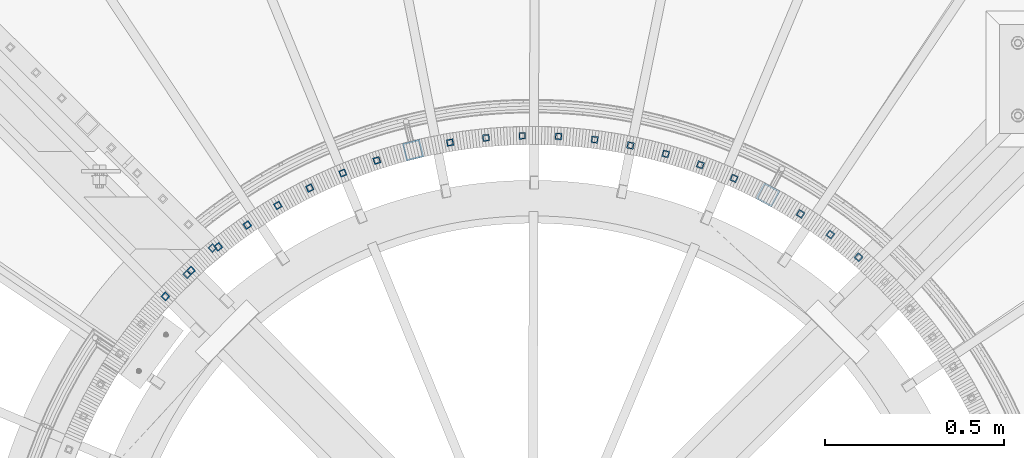
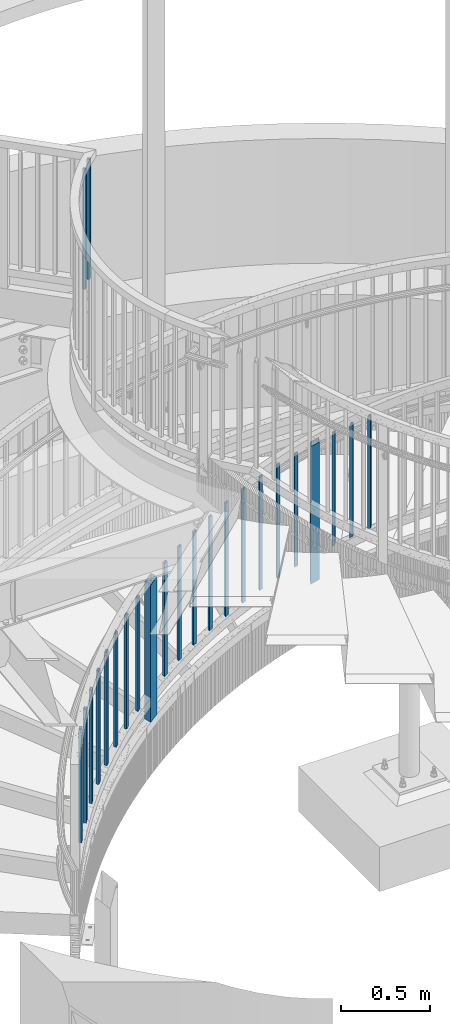
# One storey, part 264 of 975: 24 columns.
"""IFC2X3 building model written with IfcOpenShell, lengths in millimetres."""

from ifc_helpers import new_model, si_unit, frame, origin_with_axes, place, context, subcontext, project, spatial, faceted_brep, material, type_object, element, save


model = new_model("IFC2X3")

# Units and contexts
model_context = context("Model", 3, precision=1e-05, world=origin_with_axes())
body_context = subcontext(model_context, "Body", "Model", "MODEL_VIEW")
ifc_project = project(units=[si_unit("LENGTHUNIT", "METRE", prefix="MILLI"), si_unit("AREAUNIT", "SQUARE_METRE"), si_unit("VOLUMEUNIT", "CUBIC_METRE"), si_unit("MASSUNIT", "GRAM", prefix="KILO"), si_unit("TIMEUNIT", "SECOND"), si_unit("PLANEANGLEUNIT", "RADIAN"), si_unit("SOLIDANGLEUNIT", "STERADIAN"), si_unit("THERMODYNAMICTEMPERATUREUNIT", "DEGREE_CELSIUS"), si_unit("LUMINOUSINTENSITYUNIT", "LUMEN")], contexts=[model_context])

# Site, building, storey
site_placement = place(None, origin_with_axes())
site = spatial("IfcSite", under=ifc_project, at=site_placement, CompositionType="ELEMENT")
building_placement = place(site_placement, origin_with_axes())
building = spatial("IfcBuilding", under=site, at=building_placement, Name="Undefined", CompositionType="ELEMENT")
storey_placement = place(building_placement, origin_with_axes())
storey = spatial("IfcBuildingStorey", under=building, at=storey_placement, Name="Undefined", CompositionType="ELEMENT", Elevation=0.0)

# Columns
ifc_material = material()
column_type_1 = type_object("IfcColumnType", Name="HSS3/4X3/4X.120_TUBES", PredefinedType="NOTDEFINED")
for number, where, z_axis, x_axis, name in (
    (1, (33768.6107215861, 4412.96736678754, 4279.9), (-0.701517264855551, 0.712652458853252, 0.0), (0.0, 0.0, 1.0), "PICKET"),
    (2, (33839.0036411948, 4486.07693254304, 4279.9), (-0.701517264855551, 0.712652458853252, 0.0), (0.0, 0.0, 1.0), "PICKET"),
):
    element("IfcColumn", number, at=place(storey_placement, frame(where, z_axis=z_axis, x_axis=x_axis)), inside=storey, type_object=column_type_1, material=ifc_material, Name=name, ObjectType="HSS3/4X3/4X.120_TUBES", context=body_context, shape_type="Brep", body=[
        faceted_brep([(0.0, 6.34999999998763, -6.34999999998763), (0.0, -6.35000000000582, -6.34999999998763), (825.49997943247, -6.35000000000582, -6.34999999998763), (825.49997943247, 6.34999999998763, -6.34999999998763), (0.0, -6.34999999998763, 6.34999999998763), (825.49997943247, -6.34999999998763, 6.34999999998763), (0.0, 6.35000000000946, 6.34999999998763), (825.49997943247, 6.35000000000946, 6.34999999998763), (0.0, 9.52499999997963, -9.52499999997963), (0.0, 9.52500000000873, 9.5249999999869), (825.49997943247, 9.52500000000873, 9.5249999999869), (825.49997943247, 9.52499999997963, -9.52499999997963), (0.0, -9.52499999997963, 9.52499999998327), (825.49997943247, -9.52499999997963, 9.52499999998327), (0.0, -9.52500000000873, -9.5249999999869), (825.49997943247, -9.52500000000873, -9.5249999999869)], [[[0, 1, 2, 3]], [[1, 4, 5, 2]], [[4, 6, 7, 5]], [[6, 0, 3, 7]], [[8, 9, 10, 11]], [[9, 12, 13, 10]], [[12, 14, 15, 13]], [[14, 8, 11, 15]], [[13, 15, 11, 10], [5, 7, 3, 2]], [[14, 12, 9, 8], [6, 4, 1, 0]]]),
    ])
for number, where, z_axis, x_axis, name in (
    (3, (35299.2300344391, 4681.1147053438, 1598.87915234758), (0.404311668890244, 0.914621273751702, 0.0), (0.0, 0.0, 1.0), "PICKET"),
    (4, (34299.2742454818, 4731.07412125485, 929.80567844474), (-0.306869217972257, 0.951751691913965, 0.0), (0.0, 0.0, 1.0), "PICKET"),
    (5, (35204.9081284994, 4718.7730026156, 1532.20415234758), (0.336783036070548, 0.941582278197239, 0.0), (0.0, 0.0, 1.0), "PICKET"),
    (6, (34203.9654890307, 4695.93978994223, 863.72599144474), (-0.375215875823989, 0.926937455565173, 0.0), (0.0, 0.0, 1.0), "PICKET"),
    (7, (35108.0991691176, 4749.47796437935, 1465.52915234758), (0.267473826976806, 0.963565125916449, 0.0), (0.0, 0.0, 1.0), "PICKET"),
    (8, (34111.4616749303, 4653.97284259202, 796.85255444474), (-0.441578764092039, 0.897222489187017, 0.0), (0.0, 0.0, 1.0), "PICKET"),
    (9, (35009.314986428, 4773.06725313233, 1398.85415234758), (0.196750481019641, 0.980453593097878, 0.0), (0.0, 0.0, 1.0), "PICKET"),
    (10, (34022.2518719599, 4605.39515896043, 730.77286744474), (-0.50560701909387, 0.862763897160174, 0.0), (0.0, 0.0, 1.0), "PICKET"),
    (11, (34909.0778535947, 4789.41615202072, 1332.17915234758), (0.124986912061329, 0.992158390486808, 0.0), (0.0, 0.0, 1.0), "PICKET"),
    (12, (33936.8077334226, 4550.463569846, 664.69318044474), (-0.566962123933873, 0.823743861903924, 0.0), (0.0, 0.0, 1.0), "PICKET"),
    (13, (34807.9177255464, 4798.43822421916, 1265.50415234758), (0.0525625360229533, 0.998617634436142, 0.0), (0.0, 0.0, 1.0), "PICKET"),
    (14, (33855.581003508, 4489.46849922211, 598.61349344474), (-0.62531969304353, 0.780368683054327, 0.0), (0.0, 0.0, 1.0), "PICKET"),
    (15, (35648.0262873783, 4460.21419396175, 1869.27332034351), (0.654028147993579, 0.756470211992574, 0.0), (0.0, 0.0, 1.0), "PICKET"),
    (16, (34706.3694370987, 4800.08576992324, 1199.62290234758), (-0.0201397379981354, 0.999797174907674, 0.0), (0.0, 0.0, 1.0), "PICKET"),
    (17, (33779.0011289158, 4422.73242876193, 531.74005644474), (-0.680371190034262, 0.732867685036912, 0.0), (0.0, 0.0, 1.0), "PICKET"),
    (18, (35568.8338010817, 4523.80129485067, 1803.19363334351), (0.597331241111277, 0.801994631149399, 0.0), (0.0, 0.0, 1.0), "PICKET"),
    (19, (34604.9698752759, 4794.35007853899, 1134.53540234758), (-0.0927355339685746, 0.995690775662587, 0.0), (0.0, 0.0, 1.0), "PICKET"),
    (20, (33707.4729883654, 4350.60819287391, 465.66036944474), (-0.73182555599283, 0.681492006993321, 0.0), (0.0, 0.0, 1.0), "PICKET"),
    (21, (35485.2301819281, 4581.46587799922, 1737.11394634351), (0.537476235810887, 0.84327889570329, 0.0), (0.0, 0.0, 1.0), "PICKET"),
    (22, (34504.2551407829, 4781.26147473585, 1067.86040234758), (-0.1648410350661, 0.986320147395528, 0.0), (0.0, 0.0, 1.0), "PICKET"),
):
    element("IfcColumn", number, at=place(storey_placement, frame(where, z_axis=z_axis, x_axis=x_axis)), inside=storey, type_object=column_type_1, material=ifc_material, Name=name, ObjectType="HSS3/4X3/4X.120_TUBES", context=body_context, shape_type="Brep", body=[
        faceted_brep([(81.3030822565961, 6.34999999999491, -6.34999999997672), (73.0243810963957, -6.34999999999854, -6.35000000000582), (849.31820965341, -6.34999999999854, -6.35000000000582), (857.556470281766, 6.34999999999491, -6.34999999997672), (73.0243810963952, -6.34999999999127, 6.34999999998399), (849.318209653409, -6.34999999999127, 6.34999999998399), (81.3030822565956, 6.35000000000218, 6.34999999999854), (857.556470281765, 6.35000000000218, 6.34999999999854), (83.3727575466464, 9.52499999999054, -9.52499999997235), (83.3727575466455, 9.52500000000509, 9.52500000000146), (859.616035438854, 9.52500000000509, 9.52500000000146), (859.616035438854, 9.52499999999054, -9.52499999997235), (70.9547058063449, -9.5249999999869, 9.52499999997235), (847.25864449632, -9.5249999999869, 9.52499999997235), (70.9547058063458, -9.52500000000146, -9.52499999999418), (847.258644496321, -9.52500000000146, -9.52499999999418)], [[[0, 1, 2, 3]], [[1, 4, 5, 2]], [[4, 6, 7, 5]], [[6, 0, 3, 7]], [[8, 9, 10, 11]], [[9, 12, 13, 10]], [[12, 14, 15, 13]], [[14, 8, 11, 15]], [[13, 15, 11, 10], [5, 7, 3, 2]], [[14, 12, 9, 8], [6, 4, 1, 0]]]),
    ])
column_type_2 = type_object("IfcColumnType", Name="HSS2X2X.188_TUBES", PredefinedType="NOTDEFINED")
for number, where, z_axis, x_axis, name in (
    (23, (35394.2236150877, 4635.01128454125, 1516.00957038255), (0.472243102909618, 0.881468349831289, 0.0), (0.0, 0.0, 1.0), "HANDRAIL"),
    (24, (34400.7952112955, 4760.15818673421, 846.716661164317), (-0.23887243295963, 0.971050956835916, 0.0), (0.0, 0.0, 1.0), "HANDRAIL"),
):
    element("IfcColumn", number, at=place(storey_placement, frame(where, z_axis=z_axis, x_axis=x_axis)), inside=storey, type_object=column_type_2, material=ifc_material, Name=name, ObjectType="HSS2X2X.188_TUBES", context=body_context, shape_type="Brep", body=[
        faceted_brep([(73.8216023003633, 20.6375000000298, -20.6375000000116), (46.7511421721683, -20.6375000000044, -20.6374999999971), (991.653317693376, -20.6375000000044, -20.6374999999971), (1018.78995571227, 20.6375000000298, -20.6375000000116), (46.7511421721192, -20.6375000000262, 20.6375000000116), (991.653317693327, -20.6375000000262, 20.6375000000116), (73.8216023003142, 20.6375000000044, 20.6374999999953), (1018.78995571223, 20.6375000000044, 20.6374999999953), (76.9451169305453, 25.4000000000306, -25.4000000000124), (76.9451169304848, 25.4000000000051, 25.3999999999942), (1021.92110625286, 25.4000000000051, 25.3999999999942), (1021.92110625292, 25.4000000000306, -25.4000000000124), (43.6276275419368, -25.4000000000306, 25.4000000000124), (988.522167152679, -25.4000000000306, 25.4000000000124), (43.6276275419978, -25.4000000000015, -25.399999999996), (988.52216715274, -25.4000000000015, -25.399999999996)], [[[0, 1, 2, 3]], [[1, 4, 5, 2]], [[4, 6, 7, 5]], [[6, 0, 3, 7]], [[8, 9, 10, 11]], [[9, 12, 13, 10]], [[12, 14, 15, 13]], [[14, 8, 11, 15]], [[13, 15, 11, 10], [5, 7, 3, 2]], [[14, 12, 9, 8], [6, 4, 1, 0]]]),
    ])

save(model, "model.ifc")
